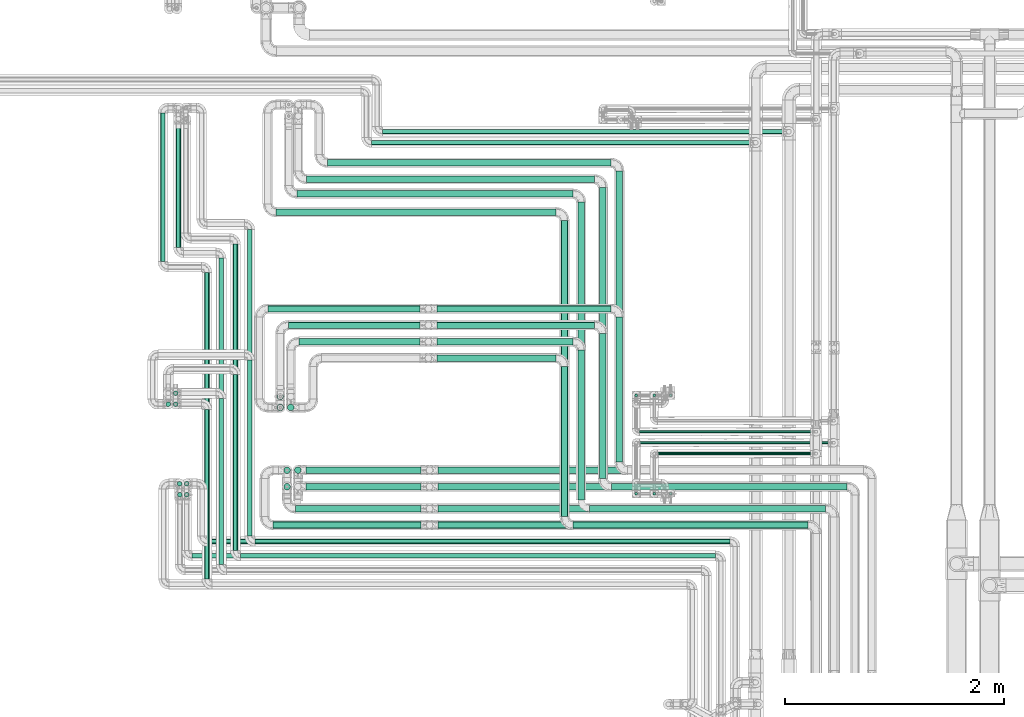
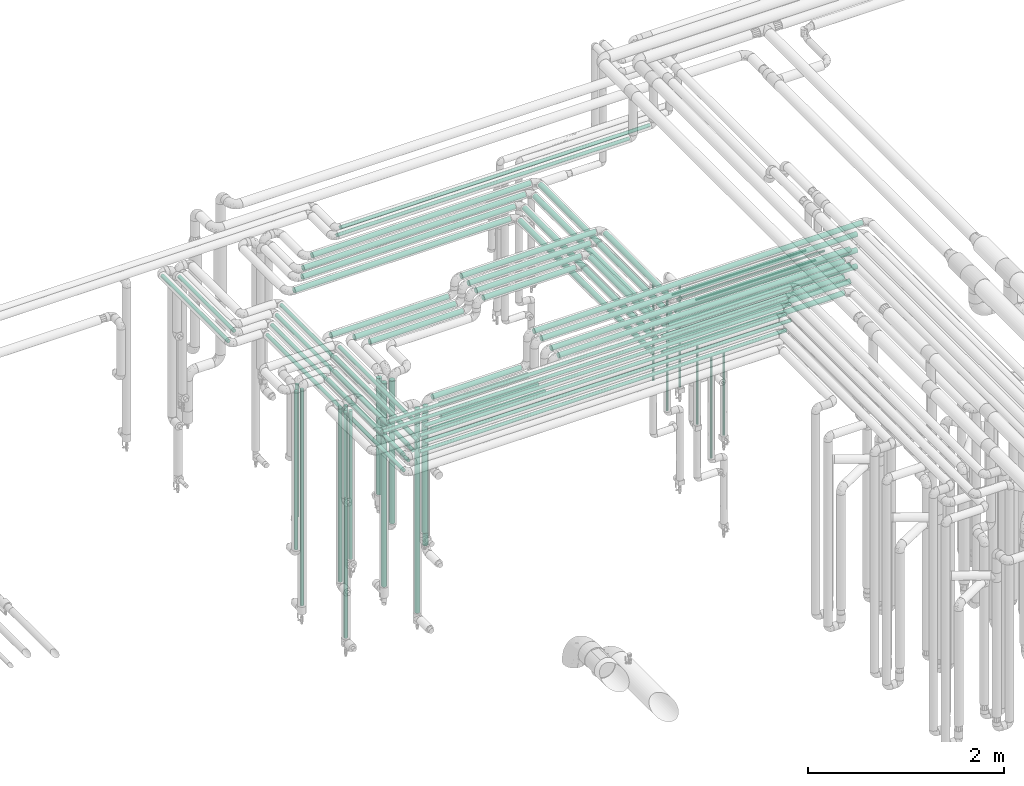
# One storey, part 532 of 827: 73 flow segments.
"""IFC2X3 building model written with IfcOpenShell, lengths in millimetres."""

from ifc_helpers import new_model, entity, si_unit, converted_unit, derived_unit, direction, frame, origin, origin_2d_with_axis, place, context, subcontext, project, spatial, circle, extrude, type_object, element, save


model = new_model("IFC2X3")

# Units and contexts
model_context = context("Model", 3, precision=0.01, world=origin(), true_north=direction((6.12303176911189e-17, 1.0)))
body_context = subcontext(model_context, "Body", "Model", "MODEL_VIEW")
ifc_project = project(units=[si_unit("LENGTHUNIT", "METRE", prefix="MILLI"), si_unit("AREAUNIT", "SQUARE_METRE"), si_unit("VOLUMEUNIT", "CUBIC_METRE"), converted_unit("PLANEANGLEUNIT", "DEGREE", entity("IfcRatioMeasure", 0.0174532925199433), si_unit("PLANEANGLEUNIT", "RADIAN"), dimensions=[0, 0, 0, 0, 0, 0, 0]), si_unit("MASSUNIT", "GRAM", prefix="KILO"), derived_unit("MASSDENSITYUNIT", [(si_unit("MASSUNIT", "GRAM", prefix="KILO"), 1), (si_unit("LENGTHUNIT", "METRE"), -3)]), derived_unit("MOMENTOFINERTIAUNIT", [(si_unit("LENGTHUNIT", "METRE"), 4)]), si_unit("TIMEUNIT", "SECOND"), si_unit("FREQUENCYUNIT", "HERTZ"), si_unit("THERMODYNAMICTEMPERATUREUNIT", "DEGREE_CELSIUS"), derived_unit("THERMALTRANSMITTANCEUNIT", [(si_unit("MASSUNIT", "GRAM", prefix="KILO"), 1), (si_unit("THERMODYNAMICTEMPERATUREUNIT", "KELVIN"), -1), (si_unit("TIMEUNIT", "SECOND"), -3)]), derived_unit("VOLUMETRICFLOWRATEUNIT", [(si_unit("LENGTHUNIT", "METRE"), 3), (si_unit("TIMEUNIT", "SECOND"), -1)]), derived_unit("MASSFLOWRATEUNIT", [(si_unit("MASSUNIT", "GRAM", prefix="KILO"), 1), (si_unit("TIMEUNIT", "SECOND"), -1)]), derived_unit("ROTATIONALFREQUENCYUNIT", [(si_unit("TIMEUNIT", "SECOND"), -1)]), si_unit("ELECTRICCURRENTUNIT", "AMPERE"), si_unit("ELECTRICVOLTAGEUNIT", "VOLT"), si_unit("POWERUNIT", "WATT"), si_unit("FORCEUNIT", "NEWTON", prefix="KILO"), si_unit("ILLUMINANCEUNIT", "LUX"), si_unit("LUMINOUSFLUXUNIT", "LUMEN"), si_unit("LUMINOUSINTENSITYUNIT", "CANDELA"), derived_unit("USERDEFINED", [(si_unit("MASSUNIT", "GRAM", prefix="KILO"), -1), (si_unit("LENGTHUNIT", "METRE"), -2), (si_unit("TIMEUNIT", "SECOND"), 3), (si_unit("LUMINOUSFLUXUNIT", "LUMEN"), 1)]), derived_unit("LINEARVELOCITYUNIT", [(si_unit("LENGTHUNIT", "METRE"), 1), (si_unit("TIMEUNIT", "SECOND"), -1)]), si_unit("PRESSUREUNIT", "PASCAL"), derived_unit("USERDEFINED", [(si_unit("LENGTHUNIT", "METRE"), -2), (si_unit("MASSUNIT", "GRAM", prefix="KILO"), 1), (si_unit("TIMEUNIT", "SECOND"), -2)]), derived_unit("LINEARFORCEUNIT", [(si_unit("MASSUNIT", "GRAM", prefix="KILO"), 1), (si_unit("LENGTHUNIT", "METRE"), 1), (si_unit("TIMEUNIT", "SECOND"), -2), (si_unit("LENGTHUNIT", "METRE"), -1)]), derived_unit("PLANARFORCEUNIT", [(si_unit("MASSUNIT", "GRAM", prefix="KILO"), 1), (si_unit("LENGTHUNIT", "METRE"), 1), (si_unit("TIMEUNIT", "SECOND"), -2), (si_unit("LENGTHUNIT", "METRE"), -2)])], contexts=[model_context])

# Site, building, storey
site_placement = place(None, origin())
site = spatial("IfcSite", under=ifc_project, at=site_placement, CompositionType="ELEMENT")
building_placement = place(site_placement, origin())
building = spatial("IfcBuilding", under=site, at=building_placement, CompositionType="ELEMENT")
storey_placement = place(building_placement, frame((0.0, 0.0, 28200.0)))
storey = spatial("IfcBuildingStorey", under=building, at=storey_placement, Name="08", CompositionType="ELEMENT", Elevation=28200.0)

# Flow segments
pipe_segment_type = type_object("IfcPipeSegmentType", PredefinedType="NOTDEFINED")
flow_segment_1_placement = place(storey_placement, frame((31545.66, 17459.61, 2968.4)))
element("IfcFlowSegment", 1, at=flow_segment_1_placement, inside=storey, type_object=pipe_segment_type, context=body_context, shape_type="SweptSolid", body=[
    extrude(circle(Radius=30.0, at=origin_2d_with_axis()), frame((0.0, 31.6, 31.6), z_axis=(1.0, 0.0, 0.0), x_axis=(0.0, -1.0, 0.0)), (0.0, 0.0, 1.0), 2553.37052000001),
])
flow_segment_2_placement = place(storey_placement, frame((34143.44, 14716.0, 2968.4)))
element("IfcFlowSegment", 2, at=flow_segment_2_placement, inside=storey, type_object=pipe_segment_type, context=body_context, shape_type="SweptSolid", body=[
    extrude(circle(Radius=30.0, at=origin_2d_with_axis()), frame((31.6, 0.0, 31.6), z_axis=(0.0, 1.0, 0.0), x_axis=(1.0, 0.0, 0.0)), (0.0, 0.0, 1.0), 2699.20292594585),
])
flow_segment_3_placement = place(storey_placement, frame((34251.03, 14608.41, 2968.4)))
element("IfcFlowSegment", 3, at=flow_segment_3_placement, inside=storey, type_object=pipe_segment_type, context=body_context, shape_type="SweptSolid", body=[
    extrude(circle(Radius=30.0, at=origin_2d_with_axis()), frame((0.0, 31.6, 31.6), z_axis=(1.0, 0.0, 0.0), x_axis=(0.0, -1.0, 0.0)), (0.0, 0.0, 1.0), 2143.00000000003),
])
flow_segment_4_placement = place(storey_placement, frame((30492.3, 17039.2, 2977.25)))
element("IfcFlowSegment", 4, at=flow_segment_4_placement, inside=storey, type_object=pipe_segment_type, context=body_context, shape_type="SweptSolid", body=[
    extrude(circle(Radius=21.15, at=origin_2d_with_axis()), frame((22.75, 0.0, 22.75), z_axis=(0.0, 1.0, 0.0), x_axis=(1.0, 0.0, 0.0)), (0.0, 0.0, 1.0), 1353.99999995382),
])
flow_segment_5_placement = place(storey_placement, frame((30634.3, 17169.2, 2977.25)))
element("IfcFlowSegment", 5, at=flow_segment_5_placement, inside=storey, type_object=pipe_segment_type, context=body_context, shape_type="SweptSolid", body=[
    extrude(circle(Radius=21.15, at=origin_2d_with_axis()), frame((22.75, 0.0, 22.75), z_axis=(0.0, 1.0, 0.0), x_axis=(1.0, 0.0, 0.0)), (0.0, 0.0, 1.0), 1124.0),
])
flow_segment_6_placement = place(storey_placement, frame((31354.52, 14467.26, 2977.25)))
element("IfcFlowSegment", 6, at=flow_segment_6_placement, inside=storey, type_object=pipe_segment_type, context=body_context, shape_type="SweptSolid", body=[
    extrude(circle(Radius=21.15, at=origin_2d_with_axis()), frame((0.0, 22.75, 22.75), z_axis=(1.0, 0.0, 0.0), x_axis=(0.0, -1.0, 0.0)), (0.0, 0.0, 1.0), 4327.51165000003),
])
flow_segment_7_placement = place(storey_placement, frame((31153.78, 14408.0, 2977.25)))
element("IfcFlowSegment", 7, at=flow_segment_7_placement, inside=storey, type_object=pipe_segment_type, context=body_context, shape_type="SweptSolid", body=[
    extrude(circle(Radius=21.15, at=origin_2d_with_axis()), frame((22.75, 0.0, 22.75), z_axis=(0.0, 1.0, 0.0), x_axis=(-1.0, 0.0, 0.0)), (0.0, 0.0, 1.0), 2795.20292594584),
])
flow_segment_8_placement = place(storey_placement, frame((31224.52, 14337.26, 2977.25)))
element("IfcFlowSegment", 8, at=flow_segment_8_placement, inside=storey, type_object=pipe_segment_type, context=body_context, shape_type="SweptSolid", body=[
    extrude(circle(Radius=21.15, at=origin_2d_with_axis()), frame((0.0, 22.75, 22.75), z_axis=(1.0, 0.0, 0.0), x_axis=(0.0, -1.0, 0.0)), (0.0, 0.0, 1.0), 4327.56910000003),
])
for number, where in (
    (9, (31023.78, 14278.0, 2977.25)),
    (10, (30893.78, 14148.0, 2977.25)),
):
    element("IfcFlowSegment", number, at=place(storey_placement, frame(where)), inside=storey, type_object=pipe_segment_type, context=body_context, shape_type="SweptSolid", body=[
        extrude(circle(Radius=21.15, at=origin_2d_with_axis()), frame((22.75, 0.0, 22.75), z_axis=(0.0, 1.0, 0.0), x_axis=(-1.0, 0.0, 0.0)), (0.0, 0.0, 1.0), 2795.20292594584),
    ])
flow_segment_9_placement = place(storey_placement, frame((31283.78, 14538.0, 2977.25)))
element("IfcFlowSegment", 11, at=flow_segment_9_placement, inside=storey, type_object=pipe_segment_type, context=body_context, shape_type="SweptSolid", body=[
    extrude(circle(Radius=21.15, at=origin_2d_with_axis()), frame((22.75, 0.0, 22.75), z_axis=(0.0, 1.0, 0.0), x_axis=(1.0, 0.0, 0.0)), (0.0, 0.0, 1.0), 2795.20292594584),
])
flow_segment_10_placement = place(storey_placement, frame((31283.78, 14538.0, 3177.25)))
element("IfcFlowSegment", 12, at=flow_segment_10_placement, inside=storey, type_object=pipe_segment_type, context=body_context, shape_type="SweptSolid", body=[
    extrude(circle(Radius=21.15, at=origin_2d_with_axis()), frame((22.75, 0.0, 22.75), z_axis=(0.0, 1.0, 0.0), x_axis=(1.0, 0.0, 0.0)), (0.0, 0.0, 1.0), 1605.20292594585),
])
flow_segment_11_placement = place(storey_placement, frame((31153.78, 14408.0, 3177.25)))
element("IfcFlowSegment", 13, at=flow_segment_11_placement, inside=storey, type_object=pipe_segment_type, context=body_context, shape_type="SweptSolid", body=[
    extrude(circle(Radius=21.15, at=origin_2d_with_axis()), frame((22.75, 0.0, 22.75), z_axis=(0.0, 1.0, 0.0), x_axis=(1.0, 0.0, 0.0)), (0.0, 0.0, 1.0), 1605.20292594584),
])
flow_segment_12_placement = place(storey_placement, frame((31023.78, 14278.0, 3177.25)))
element("IfcFlowSegment", 14, at=flow_segment_12_placement, inside=storey, type_object=pipe_segment_type, context=body_context, shape_type="SweptSolid", body=[
    extrude(circle(Radius=21.15, at=origin_2d_with_axis()), frame((22.75, 0.0, 22.75), z_axis=(0.0, 1.0, 0.0), x_axis=(1.0, 0.0, 0.0)), (0.0, 0.0, 1.0), 1515.20292594584),
])
flow_segment_13_placement = place(storey_placement, frame((30893.78, 14148.0, 3177.25)))
element("IfcFlowSegment", 15, at=flow_segment_13_placement, inside=storey, type_object=pipe_segment_type, context=body_context, shape_type="SweptSolid", body=[
    extrude(circle(Radius=21.15, at=origin_2d_with_axis()), frame((22.75, 0.0, 22.75), z_axis=(0.0, 1.0, 0.0), x_axis=(1.0, 0.0, 0.0)), (0.0, 0.0, 1.0), 1545.20292594584),
])
flow_segment_14_placement = place(storey_placement, frame((32016.66, 17909.61, 2968.4)))
element("IfcFlowSegment", 16, at=flow_segment_14_placement, inside=storey, type_object=pipe_segment_type, context=body_context, shape_type="SweptSolid", body=[
    extrude(circle(Radius=30.0, at=origin_2d_with_axis()), frame((0.0, 31.6, 31.6), z_axis=(1.0, 0.0, 0.0), x_axis=(0.0, -1.0, 0.0)), (0.0, 0.0, 1.0), 2582.37054110707),
])
flow_segment_15_placement = place(storey_placement, frame((34643.44, 15215.0, 2968.4)))
element("IfcFlowSegment", 17, at=flow_segment_15_placement, inside=storey, type_object=pipe_segment_type, context=body_context, shape_type="SweptSolid", body=[
    extrude(circle(Radius=30.0, at=origin_2d_with_axis()), frame((31.6, 0.0, 31.6), z_axis=(0.0, 1.0, 0.0), x_axis=(-1.0, 0.0, 0.0)), (0.0, 0.0, 1.0), 2650.20251676074),
])
flow_segment_16_placement = place(storey_placement, frame((31824.66, 17759.61, 2968.4)))
element("IfcFlowSegment", 18, at=flow_segment_16_placement, inside=storey, type_object=pipe_segment_type, context=body_context, shape_type="SweptSolid", body=[
    extrude(circle(Radius=30.0, at=origin_2d_with_axis()), frame((0.0, 31.6, 31.6), z_axis=(1.0, 0.0, 0.0), x_axis=(0.0, -1.0, 0.0)), (0.0, 0.0, 1.0), 2624.3705410775),
])
flow_segment_17_placement = place(storey_placement, frame((34493.44, 15065.0, 2968.4)))
element("IfcFlowSegment", 19, at=flow_segment_17_placement, inside=storey, type_object=pipe_segment_type, context=body_context, shape_type="SweptSolid", body=[
    extrude(circle(Radius=30.0, at=origin_2d_with_axis()), frame((31.6, 0.0, 31.6), z_axis=(0.0, 1.0, 0.0), x_axis=(-1.0, 0.0, 0.0)), (0.0, 0.0, 1.0), 2650.20271676073),
])
flow_segment_18_placement = place(storey_placement, frame((34601.03, 14957.41, 2968.4)))
element("IfcFlowSegment", 20, at=flow_segment_18_placement, inside=storey, type_object=pipe_segment_type, context=body_context, shape_type="SweptSolid", body=[
    extrude(circle(Radius=30.0, at=origin_2d_with_axis()), frame((0.0, 31.6, 31.6), z_axis=(1.0, 0.0, 0.0), x_axis=(0.0, -1.0, 0.0)), (0.0, 0.0, 1.0), 2148.00000000001),
])
flow_segment_19_placement = place(storey_placement, frame((31737.66, 17628.61, 2968.4)))
element("IfcFlowSegment", 21, at=flow_segment_19_placement, inside=storey, type_object=pipe_segment_type, context=body_context, shape_type="SweptSolid", body=[
    extrude(circle(Radius=30.0, at=origin_2d_with_axis()), frame((0.0, 31.6, 31.6), z_axis=(1.0, 0.0, 0.0), x_axis=(0.0, -1.0, 0.0)), (0.0, 0.0, 1.0), 2513.00001774619),
])
flow_segment_20_placement = place(storey_placement, frame((34295.07, 14866.0, 2968.4)))
element("IfcFlowSegment", 22, at=flow_segment_20_placement, inside=storey, type_object=pipe_segment_type, context=body_context, shape_type="SweptSolid", body=[
    extrude(circle(Radius=30.0, at=origin_2d_with_axis()), frame((31.6, 0.0, 31.6), z_axis=(0.0, 1.0, 0.0), x_axis=(-1.0, 0.0, 0.0)), (0.0, 0.0, 1.0), 2718.20272594582),
])
flow_segment_21_placement = place(storey_placement, frame((34402.66, 14758.41, 2968.4)))
element("IfcFlowSegment", 23, at=flow_segment_21_placement, inside=storey, type_object=pipe_segment_type, context=body_context, shape_type="SweptSolid", body=[
    extrude(circle(Radius=30.0, at=origin_2d_with_axis()), frame((0.0, 31.6, 31.6), z_axis=(1.0, 0.0, 0.0), x_axis=(0.0, -1.0, 0.0)), (0.0, 0.0, 1.0), 2150.98068574385),
])
flow_segment_22_placement = place(storey_placement, frame((34251.03, 14608.41, 3168.4)))
element("IfcFlowSegment", 24, at=flow_segment_22_placement, inside=storey, type_object=pipe_segment_type, context=body_context, shape_type="SweptSolid", body=[
    extrude(circle(Radius=30.0, at=origin_2d_with_axis()), frame((0.0, 31.6, 31.6), z_axis=(1.0, 0.0, 0.0), x_axis=(0.0, -1.0, 0.0)), (0.0, 0.0, 1.0), 2143.00000000005),
])
flow_segment_23_placement = place(storey_placement, frame((34601.03, 14957.41, 3168.4)))
element("IfcFlowSegment", 25, at=flow_segment_23_placement, inside=storey, type_object=pipe_segment_type, context=body_context, shape_type="SweptSolid", body=[
    extrude(circle(Radius=30.0, at=origin_2d_with_axis()), frame((0.0, 31.6, 31.6), z_axis=(1.0, 0.0, 0.0), x_axis=(0.0, -1.0, 0.0)), (0.0, 0.0, 1.0), 2148.00000000003),
])
flow_segment_24_placement = place(storey_placement, frame((34402.66, 14758.41, 3168.4)))
element("IfcFlowSegment", 26, at=flow_segment_24_placement, inside=storey, type_object=pipe_segment_type, context=body_context, shape_type="SweptSolid", body=[
    extrude(circle(Radius=30.0, at=origin_2d_with_axis()), frame((0.0, 31.6, 31.6), z_axis=(1.0, 0.0, 0.0), x_axis=(0.0, -1.0, 0.0)), (0.0, 0.0, 1.0), 2150.98068574388),
])
flow_segment_25_placement = place(storey_placement, frame((33021.03, 14608.41, 3368.4)))
element("IfcFlowSegment", 27, at=flow_segment_25_placement, inside=storey, type_object=pipe_segment_type, context=body_context, shape_type="SweptSolid", body=[
    extrude(circle(Radius=30.0, at=origin_2d_with_axis()), frame((0.0, 31.6, 31.6), z_axis=(1.0, 0.0, 0.0), x_axis=(0.0, 1.0, 0.0)), (0.0, 0.0, 1.0), 3373.00000900002),
])
flow_segment_26_placement = place(storey_placement, frame((33021.03, 15108.41, 3368.4)))
element("IfcFlowSegment", 28, at=flow_segment_26_placement, inside=storey, type_object=pipe_segment_type, context=body_context, shape_type="SweptSolid", body=[
    extrude(circle(Radius=30.0, at=origin_2d_with_axis()), frame((0.0, 31.6, 31.6), z_axis=(1.0, 0.0, 0.0), x_axis=(0.0, 1.0, 0.0)), (0.0, 0.0, 1.0), 3878.00000000002),
])
flow_segment_27_placement = place(storey_placement, frame((33021.03, 14958.41, 3368.4)))
element("IfcFlowSegment", 29, at=flow_segment_27_placement, inside=storey, type_object=pipe_segment_type, context=body_context, shape_type="SweptSolid", body=[
    extrude(circle(Radius=30.0, at=origin_2d_with_axis()), frame((0.0, 31.6, 31.6), z_axis=(1.0, 0.0, 0.0), x_axis=(0.0, 1.0, 0.0)), (0.0, 0.0, 1.0), 3728.00000000001),
])
flow_segment_28_placement = place(storey_placement, frame((33021.03, 14758.41, 3368.4)))
element("IfcFlowSegment", 30, at=flow_segment_28_placement, inside=storey, type_object=pipe_segment_type, context=body_context, shape_type="SweptSolid", body=[
    extrude(circle(Radius=30.0, at=origin_2d_with_axis()), frame((0.0, 31.6, 31.6), z_axis=(1.0, 0.0, 0.0), x_axis=(0.0, 1.0, 0.0)), (0.0, 0.0, 1.0), 3532.61017471227),
])
flow_segment_29_placement = place(storey_placement, frame((31354.52, 14467.26, 3177.25)))
element("IfcFlowSegment", 31, at=flow_segment_29_placement, inside=storey, type_object=pipe_segment_type, context=body_context, shape_type="SweptSolid", body=[
    extrude(circle(Radius=21.15, at=origin_2d_with_axis()), frame((0.0, 22.75, 22.75), z_axis=(1.0, 0.0, 0.0), x_axis=(0.0, 1.0, 0.0)), (0.0, 0.0, 1.0), 4327.51165000005),
])
flow_segment_30_placement = place(storey_placement, frame((31224.52, 14337.26, 3177.25)))
element("IfcFlowSegment", 32, at=flow_segment_30_placement, inside=storey, type_object=pipe_segment_type, context=body_context, shape_type="SweptSolid", body=[
    extrude(circle(Radius=21.15, at=origin_2d_with_axis()), frame((0.0, 22.75, 22.75), z_axis=(1.0, 0.0, 0.0), x_axis=(0.0, 1.0, 0.0)), (0.0, 0.0, 1.0), 4327.56910000005),
])
flow_segment_31_placement = place(storey_placement, frame((31821.03, 15108.41, 2968.4)))
element("IfcFlowSegment", 33, at=flow_segment_31_placement, inside=storey, type_object=pipe_segment_type, context=body_context, shape_type="SweptSolid", body=[
    extrude(circle(Radius=30.0, at=origin_2d_with_axis()), frame((0.0, 31.6, 31.6), z_axis=(1.0, 0.0, 0.0), x_axis=(0.0, 1.0, 0.0)), (0.0, 0.0, 1.0), 1048.00000000002),
])
flow_segment_32_placement = place(storey_placement, frame((31821.03, 14958.41, 2968.4)))
element("IfcFlowSegment", 34, at=flow_segment_32_placement, inside=storey, type_object=pipe_segment_type, context=body_context, shape_type="SweptSolid", body=[
    extrude(circle(Radius=30.0, at=origin_2d_with_axis()), frame((0.0, 31.6, 31.6), z_axis=(1.0, 0.0, 0.0), x_axis=(0.0, 1.0, 0.0)), (0.0, 0.0, 1.0), 1048.00000000003),
])
flow_segment_33_placement = place(storey_placement, frame((31517.75, 14608.41, 2968.4)))
element("IfcFlowSegment", 35, at=flow_segment_33_placement, inside=storey, type_object=pipe_segment_type, context=body_context, shape_type="SweptSolid", body=[
    extrude(circle(Radius=30.0, at=origin_2d_with_axis()), frame((0.0, 31.6, 31.6), z_axis=(1.0, 0.0, 0.0), x_axis=(0.0, 1.0, 0.0)), (0.0, 0.0, 1.0), 1351.28244),
])
flow_segment_34_placement = place(storey_placement, frame((31722.75, 14758.41, 2968.4)))
element("IfcFlowSegment", 36, at=flow_segment_34_placement, inside=storey, type_object=pipe_segment_type, context=body_context, shape_type="SweptSolid", body=[
    extrude(circle(Radius=30.0, at=origin_2d_with_axis()), frame((0.0, 31.6, 31.6), z_axis=(1.0, 0.0, 0.0), x_axis=(0.0, -1.0, 0.0)), (0.0, 0.0, 1.0), 1146.28244),
])
flow_segment_35_placement = place(storey_placement, frame((31615.16, 15107.41, 379.5)))
element("IfcFlowSegment", 37, at=flow_segment_35_placement, inside=storey, type_object=pipe_segment_type, context=body_context, shape_type="SweptSolid", body=[
    extrude(circle(Radius=30.0, at=origin_2d_with_axis()), frame((31.6, 31.6, 0.0)), (0.0, 0.0, 1.0), 2544.50000000001),
])
flow_segment_36_placement = place(storey_placement, frame((31615.16, 14957.41, 1469.5)))
element("IfcFlowSegment", 38, at=flow_segment_36_placement, inside=storey, type_object=pipe_segment_type, context=body_context, shape_type="SweptSolid", body=[
    extrude(circle(Radius=30.0, at=origin_2d_with_axis()), frame((31.6, 31.6, 0.0)), (0.0, 0.0, 1.0), 1454.50000000002),
])
flow_segment_37_placement = place(storey_placement, frame((30779.54, 14337.26, 3377.25)))
element("IfcFlowSegment", 39, at=flow_segment_37_placement, inside=storey, type_object=pipe_segment_type, context=body_context, shape_type="SweptSolid", body=[
    extrude(circle(Radius=21.15, at=origin_2d_with_axis()), frame((0.0, 22.75, 22.75), z_axis=(1.0, 0.0, 0.0), x_axis=(0.0, 1.0, 0.0)), (0.0, 0.0, 1.0), 4772.54583000002),
])
flow_segment_38_placement = place(storey_placement, frame((30921.54, 14467.26, 3377.25)))
element("IfcFlowSegment", 40, at=flow_segment_38_placement, inside=storey, type_object=pipe_segment_type, context=body_context, shape_type="SweptSolid", body=[
    extrude(circle(Radius=21.15, at=origin_2d_with_axis()), frame((0.0, 22.75, 22.75), z_axis=(1.0, 0.0, 0.0), x_axis=(0.0, 1.0, 0.0)), (0.0, 0.0, 1.0), 4760.48838000002),
])
flow_segment_39_placement = place(storey_placement, frame((30708.55, 14993.46, 455.5)))
element("IfcFlowSegment", 41, at=flow_segment_39_placement, inside=storey, type_object=pipe_segment_type, context=body_context, shape_type="SweptSolid", body=[
    extrude(circle(Radius=21.15, at=origin_2d_with_axis()), frame((22.75, 22.75, 0.0)), (0.0, 0.0, 1.0), 2896.50000000002),
])
flow_segment_40_placement = place(storey_placement, frame((30708.8, 14893.46, 1500.5)))
element("IfcFlowSegment", 42, at=flow_segment_40_placement, inside=storey, type_object=pipe_segment_type, context=body_context, shape_type="SweptSolid", body=[
    extrude(circle(Radius=21.15, at=origin_2d_with_axis()), frame((22.75, 22.75, 0.0)), (0.0, 0.0, 1.0), 1851.50000000002),
])
flow_segment_41_placement = place(storey_placement, frame((30647.59, 14893.46, 2298.45)))
element("IfcFlowSegment", 43, at=flow_segment_41_placement, inside=storey, type_object=pipe_segment_type, context=body_context, shape_type="SweptSolid", body=[
    extrude(circle(Radius=21.15, at=origin_2d_with_axis()), frame((22.75, 22.75, 0.0)), (0.0, 0.0, 1.0), 1053.55173999999),
])
flow_segment_42_placement = place(storey_placement, frame((30643.78, 14993.46, 1178.45)))
element("IfcFlowSegment", 44, at=flow_segment_42_placement, inside=storey, type_object=pipe_segment_type, context=body_context, shape_type="SweptSolid", body=[
    extrude(circle(Radius=21.15, at=origin_2d_with_axis()), frame((22.75, 22.75, 0.0)), (0.0, 0.0, 1.0), 2173.55173999987),
])
flow_segment_43_placement = place(storey_placement, frame((30540.78, 15718.46, 1178.45)))
element("IfcFlowSegment", 45, at=flow_segment_43_placement, inside=storey, type_object=pipe_segment_type, context=body_context, shape_type="SweptSolid", body=[
    extrude(circle(Radius=21.15, at=origin_2d_with_axis()), frame((22.75, 22.75, 0.0)), (0.0, 0.0, 1.0), 1973.5517399999),
])
flow_segment_44_placement = place(storey_placement, frame((30608.78, 15818.46, 1500.5)))
element("IfcFlowSegment", 46, at=flow_segment_44_placement, inside=storey, type_object=pipe_segment_type, context=body_context, shape_type="SweptSolid", body=[
    extrude(circle(Radius=21.15, at=origin_2d_with_axis()), frame((22.75, 22.75, 0.0)), (0.0, 0.0, 1.0), 1651.50000000004),
])
flow_segment_45_placement = place(storey_placement, frame((30608.78, 15718.46, 455.5)))
element("IfcFlowSegment", 47, at=flow_segment_45_placement, inside=storey, type_object=pipe_segment_type, context=body_context, shape_type="SweptSolid", body=[
    extrude(circle(Radius=21.15, at=origin_2d_with_axis()), frame((22.75, 22.75, 0.0)), (0.0, 0.0, 1.0), 2696.50000000011),
])
flow_segment_46_placement = place(storey_placement, frame((34143.44, 14716.0, 3168.4)))
element("IfcFlowSegment", 48, at=flow_segment_46_placement, inside=storey, type_object=pipe_segment_type, context=body_context, shape_type="SweptSolid", body=[
    extrude(circle(Radius=30.0, at=origin_2d_with_axis()), frame((31.6, 0.0, 31.6), z_axis=(0.0, 1.0, 0.0), x_axis=(-1.0, 0.0, 0.0)), (0.0, 0.0, 1.0), 1369.20291694587),
])
flow_segment_47_placement = place(storey_placement, frame((34643.44, 15215.0, 3168.4)))
element("IfcFlowSegment", 49, at=flow_segment_47_placement, inside=storey, type_object=pipe_segment_type, context=body_context, shape_type="SweptSolid", body=[
    extrude(circle(Radius=30.0, at=origin_2d_with_axis()), frame((31.6, 0.0, 31.6), z_axis=(0.0, 1.0, 0.0), x_axis=(1.0, 0.0, 0.0)), (0.0, 0.0, 1.0), 1320.20250776075),
])
flow_segment_48_placement = place(storey_placement, frame((34493.44, 15065.0, 3168.4)))
element("IfcFlowSegment", 50, at=flow_segment_48_placement, inside=storey, type_object=pipe_segment_type, context=body_context, shape_type="SweptSolid", body=[
    extrude(circle(Radius=30.0, at=origin_2d_with_axis()), frame((31.6, 0.0, 31.6), z_axis=(0.0, 1.0, 0.0), x_axis=(1.0, 0.0, 0.0)), (0.0, 0.0, 1.0), 1320.20271676074),
])
flow_segment_49_placement = place(storey_placement, frame((34295.07, 14866.0, 3168.4)))
element("IfcFlowSegment", 51, at=flow_segment_49_placement, inside=storey, type_object=pipe_segment_type, context=body_context, shape_type="SweptSolid", body=[
    extrude(circle(Radius=30.0, at=origin_2d_with_axis()), frame((31.6, 0.0, 31.6), z_axis=(0.0, 1.0, 0.0), x_axis=(1.0, 0.0, 0.0)), (0.0, 0.0, 1.0), 1369.20271676073),
])
flow_segment_50_placement = place(storey_placement, frame((33011.03, 16129.61, 3168.4)))
element("IfcFlowSegment", 52, at=flow_segment_50_placement, inside=storey, type_object=pipe_segment_type, context=body_context, shape_type="SweptSolid", body=[
    extrude(circle(Radius=30.0, at=origin_2d_with_axis()), frame((0.0, 31.6, 31.6), z_axis=(1.0, 0.0, 0.0), x_axis=(0.0, 1.0, 0.0)), (0.0, 0.0, 1.0), 1088.00000000002),
])
flow_segment_51_placement = place(storey_placement, frame((33011.03, 16279.61, 3168.4)))
element("IfcFlowSegment", 53, at=flow_segment_51_placement, inside=storey, type_object=pipe_segment_type, context=body_context, shape_type="SweptSolid", body=[
    extrude(circle(Radius=30.0, at=origin_2d_with_axis()), frame((0.0, 31.6, 31.6), z_axis=(1.0, 0.0, 0.0), x_axis=(0.0, 1.0, 0.0)), (0.0, 0.0, 1.0), 1239.62947996842),
])
flow_segment_52_placement = place(storey_placement, frame((33011.03, 16429.61, 3168.4)))
element("IfcFlowSegment", 54, at=flow_segment_52_placement, inside=storey, type_object=pipe_segment_type, context=body_context, shape_type="SweptSolid", body=[
    extrude(circle(Radius=30.0, at=origin_2d_with_axis()), frame((0.0, 31.6, 31.6), z_axis=(1.0, 0.0, 0.0), x_axis=(0.0, 1.0, 0.0)), (0.0, 0.0, 1.0), 1437.99999100004),
])
flow_segment_53_placement = place(storey_placement, frame((33011.03, 16579.61, 3168.4)))
element("IfcFlowSegment", 55, at=flow_segment_53_placement, inside=storey, type_object=pipe_segment_type, context=body_context, shape_type="SweptSolid", body=[
    extrude(circle(Radius=30.0, at=origin_2d_with_axis()), frame((0.0, 31.6, 31.6), z_axis=(1.0, 0.0, 0.0), x_axis=(0.0, 1.0, 0.0)), (0.0, 0.0, 1.0), 1587.99999100001),
])
flow_segment_54_placement = place(storey_placement, frame((31756.25, 16279.61, 2968.4)))
element("IfcFlowSegment", 56, at=flow_segment_54_placement, inside=storey, type_object=pipe_segment_type, context=body_context, shape_type="SweptSolid", body=[
    extrude(circle(Radius=30.0, at=origin_2d_with_axis()), frame((0.0, 31.6, 31.6), z_axis=(1.0, 0.0, 0.0), x_axis=(0.0, 1.0, 0.0)), (0.0, 0.0, 1.0), 1102.78000899999),
])
flow_segment_55_placement = place(storey_placement, frame((31660.25, 16429.61, 2968.4)))
element("IfcFlowSegment", 57, at=flow_segment_55_placement, inside=storey, type_object=pipe_segment_type, context=body_context, shape_type="SweptSolid", body=[
    extrude(circle(Radius=30.0, at=origin_2d_with_axis()), frame((0.0, 31.6, 31.6), z_axis=(1.0, 0.0, 0.0), x_axis=(0.0, 1.0, 0.0)), (0.0, 0.0, 1.0), 1198.77996899999),
])
flow_segment_56_placement = place(storey_placement, frame((31471.03, 16579.61, 2968.4)))
element("IfcFlowSegment", 58, at=flow_segment_56_placement, inside=storey, type_object=pipe_segment_type, context=body_context, shape_type="SweptSolid", body=[
    extrude(circle(Radius=30.0, at=origin_2d_with_axis()), frame((0.0, 31.6, 31.6), z_axis=(1.0, 0.0, 0.0), x_axis=(0.0, 1.0, 0.0)), (0.0, 0.0, 1.0), 1388.00000000001),
])
flow_segment_57_placement = place(storey_placement, frame((31648.66, 15679.61, 1136.0)))
element("IfcFlowSegment", 59, at=flow_segment_57_placement, inside=storey, type_object=pipe_segment_type, context=body_context, shape_type="SweptSolid", body=[
    extrude(circle(Radius=30.0, at=origin_2d_with_axis()), frame((31.6, 31.6, 0.0)), (0.0, 0.0, 1.0), 1788.00000000001),
])
flow_segment_58_placement = place(storey_placement, frame((31552.66, 15679.61, 379.5)))
element("IfcFlowSegment", 60, at=flow_segment_58_placement, inside=storey, type_object=pipe_segment_type, context=body_context, shape_type="SweptSolid", body=[
    extrude(circle(Radius=30.0, at=origin_2d_with_axis()), frame((31.6, 31.6, 0.0)), (0.0, 0.0, 1.0), 2544.50000000001),
])
flow_segment_59_placement = place(storey_placement, frame((31552.66, 15779.61, 1469.5)))
element("IfcFlowSegment", 61, at=flow_segment_59_placement, inside=storey, type_object=pipe_segment_type, context=body_context, shape_type="SweptSolid", body=[
    extrude(circle(Radius=30.0, at=origin_2d_with_axis()), frame((31.6, 31.6, 0.0)), (0.0, 0.0, 1.0), 1454.50000000001),
])
flow_segment_60_placement = place(storey_placement, frame((32418.03, 18102.16, 2976.76)))
element("IfcFlowSegment", 62, at=flow_segment_60_placement, inside=storey, type_object=pipe_segment_type, context=body_context, shape_type="SweptSolid", body=[
    extrude(circle(Radius=21.15, at=origin_2d_with_axis()), frame((0.0, 22.75, 22.75), z_axis=(1.0, -2.64804923458866e-08, 0.0), x_axis=(-2.64804923458866e-08, -1.0, 0.0)), (0.0, 0.0, 1.0), 3452.34056165481),
])
flow_segment_61_placement = place(storey_placement, frame((32515.53, 18202.2, 2977.42)))
element("IfcFlowSegment", 63, at=flow_segment_61_placement, inside=storey, type_object=pipe_segment_type, context=body_context, shape_type="SweptSolid", body=[
    extrude(circle(Radius=21.15, at=origin_2d_with_axis()), frame((0.0, 22.75, 22.75), z_axis=(1.0, 0.0, 0.0), x_axis=(0.0, -1.0, 0.0)), (0.0, 0.0, 1.0), 3656.50789865934),
])
flow_segment_62_placement = place(storey_placement, frame((34856.95, 15475.0, 2985.0)))
element("IfcFlowSegment", 64, at=flow_segment_62_placement, inside=storey, type_object=pipe_segment_type, context=body_context, shape_type="SweptSolid", body=[
    extrude(circle(Radius=13.4, at=origin_2d_with_axis()), frame((0.0, 15.0, 15.0), z_axis=(1.0, 0.0, 0.0), x_axis=(0.0, 1.0, 0.0)), (0.0, 0.0, 1.0), 1582.6706783036),
])
flow_segment_63_placement = place(storey_placement, frame((35021.98, 15275.0, 2985.0)))
element("IfcFlowSegment", 65, at=flow_segment_63_placement, inside=storey, type_object=pipe_segment_type, context=body_context, shape_type="SweptSolid", body=[
    extrude(circle(Radius=13.4, at=origin_2d_with_axis()), frame((0.0, 15.0, 15.0), z_axis=(1.0, 0.0, 0.0), x_axis=(0.0, -1.0, 0.0)), (0.0, 0.0, 1.0), 1417.63184830361),
])
flow_segment_64_placement = place(storey_placement, frame((34977.89, 15807.05, 1309.1)))
element("IfcFlowSegment", 66, at=flow_segment_64_placement, inside=storey, type_object=pipe_segment_type, context=body_context, shape_type="SweptSolid", body=[
    extrude(circle(Radius=13.4, at=origin_2d_with_axis()), frame((15.0, 15.0, 0.0), z_axis=(0.0, 0.0, 1.0), x_axis=(-1.0, 0.0, 0.0)), (0.0, 0.0, 1.0), 1511.9),
])
flow_segment_65_placement = place(storey_placement, frame((35127.89, 15807.05, 1549.85)))
element("IfcFlowSegment", 67, at=flow_segment_65_placement, inside=storey, type_object=pipe_segment_type, context=body_context, shape_type="SweptSolid", body=[
    extrude(circle(Radius=13.4, at=origin_2d_with_axis()), frame((15.0, 15.0, 0.0)), (0.0, 0.0, 1.0), 1271.05113227306),
])
flow_segment_66_placement = place(storey_placement, frame((34856.95, 15374.6, 2985.0)))
element("IfcFlowSegment", 68, at=flow_segment_66_placement, inside=storey, type_object=pipe_segment_type, context=body_context, shape_type="SweptSolid", body=[
    extrude(circle(Radius=13.4, at=origin_2d_with_axis()), frame((0.0, 15.0, 15.0), z_axis=(1.0, 0.0, 0.0), x_axis=(0.0, 1.0, 0.0)), (0.0, 0.0, 1.0), 1743.59767471228),
])
flow_segment_67_placement = place(storey_placement, frame((34812.85, 15807.05, 1739.0)))
element("IfcFlowSegment", 69, at=flow_segment_67_placement, inside=storey, type_object=pipe_segment_type, context=body_context, shape_type="SweptSolid", body=[
    extrude(circle(Radius=13.4, at=origin_2d_with_axis()), frame((15.0, 15.0, 0.0)), (0.0, 0.0, 1.0), 1232.1001152873),
])
flow_segment_68_placement = place(storey_placement, frame((34812.85, 14909.92, 1739.0)))
element("IfcFlowSegment", 70, at=flow_segment_68_placement, inside=storey, type_object=pipe_segment_type, context=body_context, shape_type="SweptSolid", body=[
    extrude(circle(Radius=13.4, at=origin_2d_with_axis()), frame((15.0, 15.0, 0.0)), (0.0, 0.0, 1.0), 1031.9),
])
flow_segment_69_placement = place(storey_placement, frame((31713.44, 15108.41, 1186.0)))
element("IfcFlowSegment", 71, at=flow_segment_69_placement, inside=storey, type_object=pipe_segment_type, context=body_context, shape_type="SweptSolid", body=[
    extrude(circle(Radius=30.0, at=origin_2d_with_axis()), frame((31.6, 31.6, 0.0), z_axis=(0.0, 0.0, 1.0), x_axis=(-1.0, 0.0, 0.0)), (0.0, 0.0, 1.0), 1738.00000000001),
])
flow_segment_70_placement = place(storey_placement, frame((35127.89, 14909.92, 1492.5)))
element("IfcFlowSegment", 72, at=flow_segment_70_placement, inside=storey, type_object=pipe_segment_type, context=body_context, shape_type="SweptSolid", body=[
    extrude(circle(Radius=13.4, at=origin_2d_with_axis()), frame((15.0, 15.0, 0.0), z_axis=(0.0, 0.0, 1.0), x_axis=(-1.0, 0.0, 0.0)), (0.0, 0.0, 1.0), 1058.40000000002),
])
flow_segment_71_placement = place(storey_placement, frame((34977.89, 14909.92, 1259.1)))
element("IfcFlowSegment", 73, at=flow_segment_71_placement, inside=storey, type_object=pipe_segment_type, context=body_context, shape_type="SweptSolid", body=[
    extrude(circle(Radius=13.4, at=origin_2d_with_axis()), frame((15.0, 15.0, 0.0), z_axis=(0.0, 0.0, 1.0), x_axis=(-1.0, 0.0, 0.0)), (0.0, 0.0, 1.0), 1291.90000000004),
])

save(model, "model.ifc")
